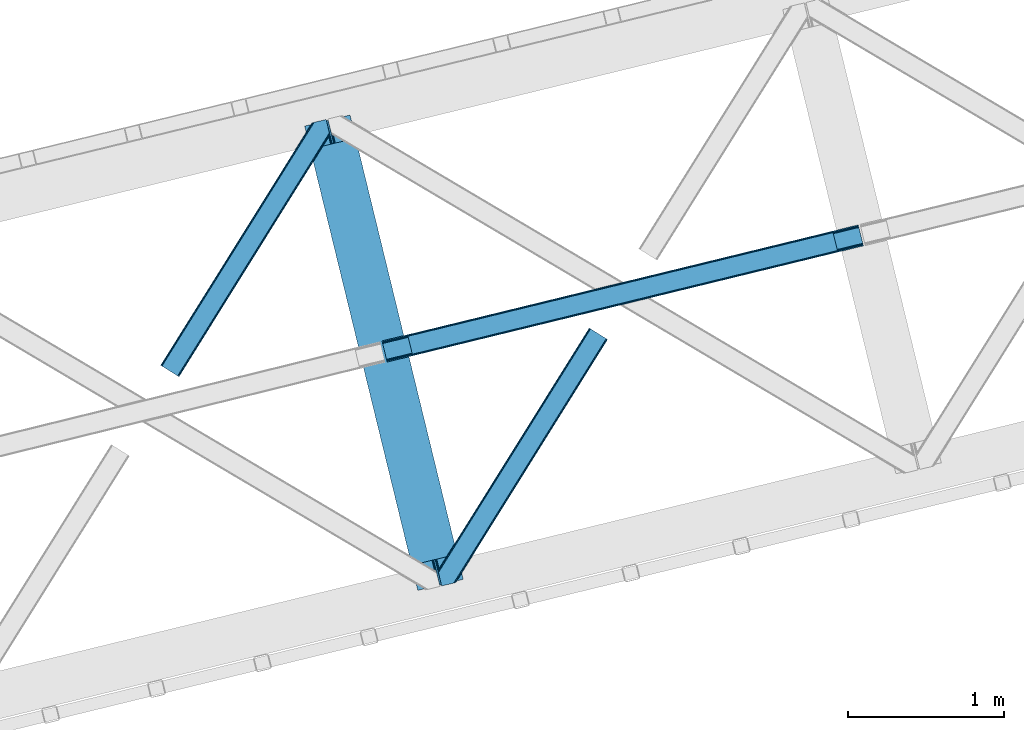
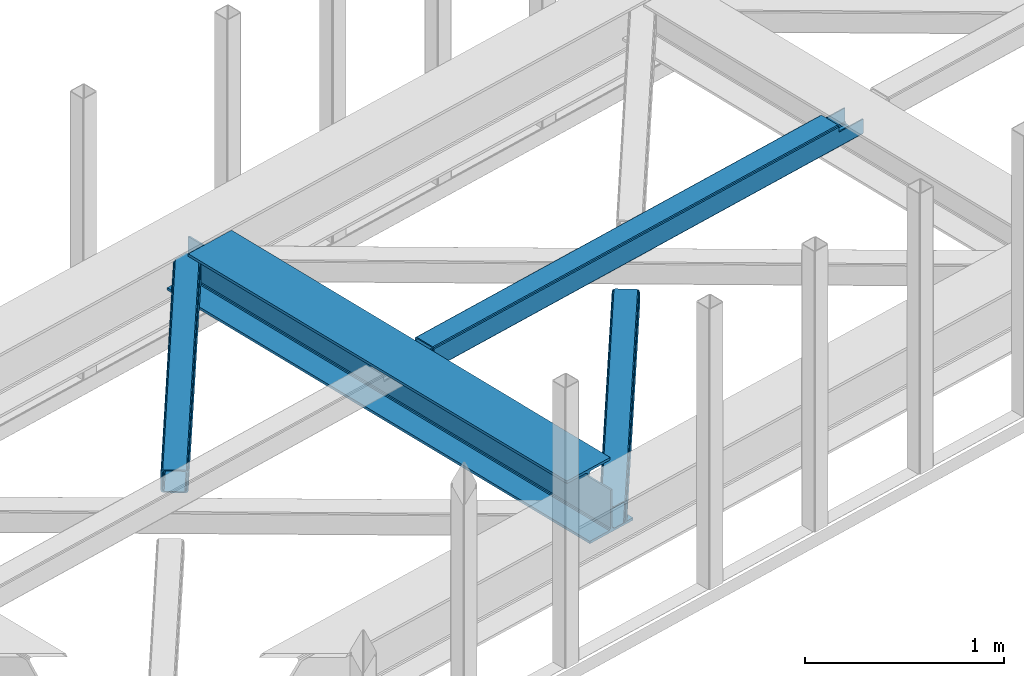
# One storey, part 40 of 67: 2 beams, 2 members.
"""IFC4 building model written with IfcOpenShell, lengths in millimetres."""

from ifc_helpers import new_model, entity, si_unit, converted_unit, derived_unit, direction, frame, origin, place, context, subcontext, project, spatial, triangles, polygons, material, type_object, element, save


model = new_model("IFC4")

# Units and contexts
model_context = context("Model", 3, precision=0.01, world=origin(), true_north=direction((6.12303176911189e-17, 1.0)))
plan_context = context("Plan", 3, precision=0.01, world=origin(), true_north=direction((6.12303176911189e-17, 1.0)))
body_context = subcontext(model_context, "Body", "Model", "MODEL_VIEW")
ifc_project = project(units=[si_unit("LENGTHUNIT", "METRE", prefix="MILLI"), si_unit("AREAUNIT", "SQUARE_METRE"), si_unit("VOLUMEUNIT", "CUBIC_METRE"), converted_unit("PLANEANGLEUNIT", "DEGREE", entity("IfcRatioMeasure", 0.0174532925199433), si_unit("PLANEANGLEUNIT", "RADIAN"), dimensions=[0, 0, 0, 0, 0, 0, 0]), si_unit("MASSUNIT", "GRAM", prefix="KILO"), derived_unit("MASSDENSITYUNIT", [(si_unit("MASSUNIT", "GRAM", prefix="KILO"), 1), (si_unit("LENGTHUNIT", "METRE"), -3)]), derived_unit("MOMENTOFINERTIAUNIT", [(si_unit("LENGTHUNIT", "METRE"), 4)]), si_unit("TIMEUNIT", "SECOND"), si_unit("FREQUENCYUNIT", "HERTZ"), si_unit("THERMODYNAMICTEMPERATUREUNIT", "DEGREE_CELSIUS"), derived_unit("THERMALTRANSMITTANCEUNIT", [(si_unit("MASSUNIT", "GRAM", prefix="KILO"), 1), (si_unit("THERMODYNAMICTEMPERATUREUNIT", "KELVIN"), -1), (si_unit("TIMEUNIT", "SECOND"), -3)]), derived_unit("VOLUMETRICFLOWRATEUNIT", [(si_unit("LENGTHUNIT", "METRE"), 3), (si_unit("TIMEUNIT", "SECOND"), -1)]), derived_unit("MASSFLOWRATEUNIT", [(si_unit("MASSUNIT", "GRAM", prefix="KILO"), 1), (si_unit("TIMEUNIT", "SECOND"), -1)]), derived_unit("ROTATIONALFREQUENCYUNIT", [(si_unit("TIMEUNIT", "SECOND"), -1)]), si_unit("ELECTRICCURRENTUNIT", "AMPERE"), si_unit("ELECTRICVOLTAGEUNIT", "VOLT"), si_unit("POWERUNIT", "WATT"), si_unit("FORCEUNIT", "NEWTON", prefix="KILO"), si_unit("ILLUMINANCEUNIT", "LUX"), si_unit("LUMINOUSFLUXUNIT", "LUMEN"), si_unit("LUMINOUSINTENSITYUNIT", "CANDELA"), derived_unit("USERDEFINED", [(si_unit("MASSUNIT", "GRAM", prefix="KILO"), -1), (si_unit("LENGTHUNIT", "METRE"), -2), (si_unit("TIMEUNIT", "SECOND"), 3), (si_unit("LUMINOUSFLUXUNIT", "LUMEN"), 1)]), derived_unit("LINEARVELOCITYUNIT", [(si_unit("LENGTHUNIT", "METRE"), 1), (si_unit("TIMEUNIT", "SECOND"), -1)]), si_unit("PRESSUREUNIT", "PASCAL"), derived_unit("USERDEFINED", [(si_unit("LENGTHUNIT", "METRE"), -2), (si_unit("MASSUNIT", "GRAM", prefix="KILO"), 1), (si_unit("TIMEUNIT", "SECOND"), -2)]), derived_unit("LINEARFORCEUNIT", [(si_unit("MASSUNIT", "GRAM", prefix="KILO"), 1), (si_unit("LENGTHUNIT", "METRE"), 1), (si_unit("TIMEUNIT", "SECOND"), -2), (si_unit("LENGTHUNIT", "METRE"), -1)]), derived_unit("PLANARFORCEUNIT", [(si_unit("MASSUNIT", "GRAM", prefix="KILO"), 1), (si_unit("LENGTHUNIT", "METRE"), 1), (si_unit("TIMEUNIT", "SECOND"), -2), (si_unit("LENGTHUNIT", "METRE"), -2)])], contexts=[model_context, plan_context])

# Site, building, storey
site_placement = place(None, origin())
site = spatial("IfcSite", under=ifc_project, at=site_placement, CompositionType="ELEMENT")
building_placement = place(site_placement, origin())
building = spatial("IfcBuilding", under=site, at=building_placement, CompositionType="ELEMENT")
storey_placement = place(building_placement, frame((0.0, 0.0, 19800.0)))
storey = spatial("IfcBuildingStorey", under=building, at=storey_placement, CompositionType="ELEMENT", Elevation=19800.0)

# Beams
ifc_material = material(Name="Metal painted (White)")
beam_type = type_object("IfcBeamType", PredefinedType="BEAM")
beam_1_placement = place(storey_placement, frame((-27234.9251460859, 11156.1280684599, 3807.02022389142)))
element("IfcBeam", 1, at=beam_1_placement, inside=storey, type_object=beam_type, material=ifc_material, ObjectType="Steel Beam", PredefinedType="BEAM", context=body_context, shape_type="Tessellation", body=[
    polygons([(1018.16648378329, 71.0478278970978, 15.5000000000008), (1018.16648378329, 71.0478278970978, 0.0), (291.465617442442, 3052.25531830421, 0.0), (291.465617442438, 3052.25531830421, 15.5000000000008), (894.779372399329, 40.970914087327, 15.5000000000008), (168.078506058478, 3022.17840449444, 15.5000000000008), (888.087028625371, 39.3395844888221, 16.8701684147984), (161.38616228452, 3020.54707489593, 16.8701684147984), (882.413533524751, 37.9566100336497, 20.7720779386434), (155.7126671839, 3019.16410044076, 20.7720779386434), (878.622625296176, 37.0325360459162, 26.6116982174294), (151.921758955325, 3018.24002645303, 26.6116982174294), (877.291435352783, 36.7080444135007, 33.500000000001), (150.590569011928, 3017.91553482061, 33.500000000001), (140.875048430518, 3015.54727389071, 33.500000000001), (140.875048430518, 3015.54727389071, 259.000000000002), (150.590569011928, 3017.91553482061, 259.000000000002), (0.0, 2981.20749040711, 0.0), (0.0, 2981.20749040711, 15.4999999999965), (123.387111383968, 3011.28440421688, 15.5000000000008), (130.079455157922, 3012.91573381539, 16.8701684147984), (135.752950258546, 3014.29870827056, 20.7720779386391), (139.543858487122, 3015.2227822583, 26.6116982174294), (877.291435352783, 36.7080444135007, 259.000000000002), (867.575914771365, 34.3397834835992, 259.000000000002), (867.575914771365, 34.3397834835992, 33.500000000001), (866.244724827968, 34.0152918511816, 26.6116982174294), (862.453816599393, 33.0912178634481, 20.7720779386391), (856.780321498769, 31.7082434082757, 16.8701684147984), (850.087977724815, 30.076913809773, 15.5000000000008), (726.700866340847, 0.0, 15.4999999999965), (726.700866340847, -2.16573425859679e-12, 0.0), (838.124523615916, 197.385937999179, 259.069791973884), (186.469722099971, 2870.72539801218, 259.000000000002), (186.693115201825, 2869.80895360721, 259.617303331124), (186.70550404545, 2869.75812937344, 266.500003008253), (837.979344808147, 197.981416001704, 266.500002998871), (837.979694928895, 197.979979696968, 260.000004007589), (828.499586345876, 194.645865944429, 259.006343171919), (828.276216326107, 195.562317481909, 259.617303331124), (828.263827482481, 195.613141715683, 266.500003008253), (176.989986719784, 2867.38985508742, 266.500002998871), (176.989636599036, 2867.39129139215, 260.000004007589), (176.844830940692, 2867.98534020594, 259.07612046749), (176.754201518548, 2868.35713708228, 259.000000000002), (839.310832678066, 198.304685446386, 273.388305639783), (843.101109266766, 199.231350618303, 279.227924098781), (848.7741802143, 200.616065081979, 283.129832400619), (855.466371895434, 202.24801861279, 284.500000377228), (978.853400583269, 232.3252716679, 284.500000138971), (978.851730776613, 232.332121736633, 299.999995328161), (687.386308679343, 161.283492472591, 299.999995890962), (687.387978486003, 161.276642403861, 284.500000701776), (810.775007173847, 191.353895458972, 284.500000463519), (817.467494069986, 192.984637925548, 283.129832461069), (823.141405718746, 194.365903570074, 279.227924137322), (826.932940505738, 195.28740721937, 273.388305663684), (175.658498849852, 2867.06658564273, 273.388305639783), (171.868222261156, 2866.13992047082, 279.227924098781), (166.195151313627, 2864.75520600714, 283.129832400619), (159.502959632497, 2863.12325247633, 284.500000377228), (36.115930944649, 2833.04599942122, 284.500000138971), (36.1176007513094, 2833.03914935249, 299.999995328161), (327.583022848575, 2904.08777861653, 299.999995890962), (327.581353041919, 2904.09462868526, 284.500000701776), (204.194324354084, 2874.01737563015, 284.500000463519), (197.501837457941, 2872.38663316357, 283.129832461069), (191.827925809181, 2871.00536751904, 279.227924137322), (188.036391022185, 2870.08386386975, 273.388305663684)], [[[1, 2, 3, 4]], [[5, 1, 4, 6]], [[7, 5, 6, 8]], [[9, 7, 8, 10]], [[11, 9, 10, 12]], [[13, 11, 12, 14]], [[15, 16, 17, 14, 12, 10, 8, 6, 4, 3, 18, 19, 20, 21, 22, 23]], [[13, 24, 25, 26, 27, 28, 29, 30, 31, 32, 2, 1, 5, 7, 9, 11]], [[2, 32, 18, 3]], [[32, 31, 19, 18]], [[31, 30, 20, 19]], [[27, 26, 15, 23]], [[28, 27, 23, 22]], [[29, 28, 22, 21]], [[30, 29, 21, 20]], [[33, 24, 13, 14, 17, 34, 35, 36, 37, 38]], [[25, 39, 40, 41, 42, 43, 44, 16, 15, 26]], [[39, 25, 24, 33]], [[45, 34, 17, 16]], [[41, 40, 38, 37, 46, 47, 48, 49, 50, 51, 52, 53, 54, 55, 56, 57]], [[42, 58, 59, 60, 61, 62, 63, 64, 65, 66, 67, 68, 69, 36, 35, 43]], [[46, 37, 36, 69]], [[47, 46, 69, 68]], [[48, 47, 68, 67]], [[49, 48, 67, 66]], [[50, 49, 66, 65]], [[51, 50, 65, 64]], [[52, 51, 64, 63]], [[53, 52, 63, 62]], [[54, 53, 62, 61]], [[55, 54, 61, 60]], [[56, 55, 60, 59]], [[57, 56, 59, 58]], [[41, 57, 58, 42]]], closed=False),
])
beam_2_placement = place(storey_placement, frame((-26738.1889944825, 12622.2260164925, 3967.02022389142)))
element("IfcBeam", 2, at=beam_2_placement, inside=storey, type_object=beam_type, material=ifc_material, ObjectType="Steel Beam", PredefinedType="BEAM", context=body_context, shape_type="Tessellation", body=[
    polygons([(31.1823923917614, 8.09507685196108, 17.8030399336114), (31.4978703677143, 6.80086440699217, 24.4999999999988), (3089.94374939705, 752.329405140566, 24.4999999999988), (3089.62827142109, 753.623617585535, 17.8030399336114), (30.2839871259035, 11.7806820741864, 12.1256313292298), (3088.72986615524, 757.309222807764, 12.1256313292298), (28.9394286278148, 17.2965800886753, 8.33210818105214), (3087.38530765716, 762.825120822251, 8.33210818105214), (27.3534137403861, 23.8030254244661, 7.00000000000274), (3085.79929276972, 769.331566158042, 7.00000000000274), (4.21622439082827, 118.720708051131, 8.33210818105214), (5.80223927826556, 112.214262715341, 7.00000000000274), (3064.2481183076, 857.742803448919, 7.00000000000274), (3062.66210342017, 864.249248784707, 8.33210818105214), (2.87166589274391, 124.236606065618, 12.1256313292342), (3061.31754492208, 869.765146799196, 12.1256313292342), (1.9732606268946, 127.922211287846, 17.8030399336114), (3060.41913965623, 873.450752021424, 17.8030399336114), (1.65778265093302, 129.216423732817, 24.4999999999988), (3060.10366168026, 874.744964466395, 24.4999999999988), (33.1556530186517, 0.0, 17.5000000000004), (33.1556530186517, 0.0, 99.499999999999), (31.497870367723, 6.80086440699001, 99.499999999999), (1.65778265093735, 129.216423732817, 99.499999999999), (4.33146851719357e-12, 136.017288139807, 99.499999999999), (4.33146851719357e-12, 136.017288139807, 17.5000000000004), (0.315477975965916, 134.723075694838, 10.803039933613), (1.21388324181955, 131.037470472612, 5.12563132923143), (2.55844173990391, 125.521572458124, 1.33210818105373), (4.14445662733254, 119.015127122331, 0.0), (29.0111963913192, 17.0021610174761, 0.0), (30.5972112787564, 10.4957156816853, 1.33210818105373), (31.9417697768408, 4.97981766719418, 5.12563132923576), (32.8401750426901, 1.29421244496891, 10.803039933613), (3058.44587902933, 881.54582887338, 17.5000000000004), (3058.44587902933, 881.54582887338, 99.499999999999), (3060.10366168026, 874.74496446639, 99.499999999999), (3089.94374939704, 752.329405140566, 99.499999999999), (3091.60153204797, 745.528540733574, 99.499999999999), (3091.60153204797, 745.528540733574, 17.5000000000004), (3091.28605407202, 746.822753178543, 10.803039933613), (3090.38764880616, 750.508358400766, 5.12563132923576), (3089.04309030808, 756.024256415259, 1.33210818105373), (3087.45707542064, 762.53070175105, 0.0), (3062.59033565666, 864.543667855904, 0.0), (3061.00432076922, 871.050113191697, 1.33210818105373), (3059.65976227114, 876.566011206186, 5.12563132923143), (3058.76135700529, 880.251616428411, 10.803039933613), (2925.75994180941, 712.307865540878, 115.5000123926), (2925.81630989428, 712.321604759496, 100.117303289864), (2926.72300362928, 712.542621518191, 99.499999999999), (194.718606580805, 46.5876811586757, 99.5063429816656), (195.631369831917, 46.8101414945052, 100.117301735448), (195.690168193631, 46.824474122359, 115.5), (2928.38078628021, 705.741757111199, 99.499999999999), (2927.47422618797, 705.520772937691, 100.117303484932), (2927.41464342029, 705.506249905349, 122.500007895425), (197.345360928052, 40.0229783796067, 122.500002534479), (197.338587096745, 40.02132714415, 100.500009163303), (196.74820519572, 39.8773799905087, 99.5697919021647), (2896.88292546718, 834.958147714707, 99.5063429816656), (2895.97381660772, 834.736577551995, 100.117299778624), (2895.91744852285, 834.722838333377, 115.50000888136), (165.850080476841, 169.240033448183, 115.5), (165.840462203343, 169.237688832044, 100.50000941238), (165.250325295037, 169.093836777333, 99.5761204674868), (2894.85332685227, 841.668448882878, 99.5697919021647), (163.220745767773, 175.804071762186, 99.499999999999), (164.133244938519, 176.026503182399, 100.117301984524), (164.189439987632, 176.040201208968, 122.500002796667), (2894.25631754634, 841.522886341455, 122.500003994045), (2894.26642083517, 841.525349756027, 100.500018741102), (2894.56843170073, 840.227853719294, 129.196959150505), (2895.46176722632, 836.541012377604, 134.874360354937), (2896.80305823039, 831.024317672795, 138.667878733795), (2898.38810531639, 824.51763636472, 139.999985502214), (2923.25885436332, 722.505647815409, 139.999991354279), (2924.84634848091, 715.999563150004, 138.667885332354), (2926.19460804134, 710.484567539777, 134.874367586349), (2927.09837274855, 706.800269072823, 129.196966804773), (2925.44675217771, 713.602635936895, 122.196975799125), (2924.54298747049, 717.286934403852, 127.874376580702), (2923.19472791006, 722.801930014079, 131.667894326702), (2921.60723379248, 729.308014679482, 133.000000348631), (2900.05258461847, 817.71840475555, 132.999995276841), (2898.46753753246, 824.225086063627, 131.667888508414), (2897.1262465284, 829.74178076843, 127.874370129564), (2896.23291100281, 833.428622110126, 122.196968925133), (164.878528418706, 169.003207355194, 99.499999999999), (193.131726453732, 57.3201898040399, 131.667891818946), (191.545711566294, 63.8266351398329, 133.0), (194.476284951812, 51.8042917895531, 127.874368670764), (195.37469021767, 48.1186865673279, 122.196960066391), (169.994537104174, 152.237872430709, 133.0), (166.165558452803, 167.945821003215, 122.196960066391), (167.063963718652, 164.260215780989, 127.874368670764), (168.408522216736, 158.744317766502, 131.667891818946), (197.031411944078, 41.3175635421159, 129.196961104604), (196.136488323061, 45.0040174739024, 134.874366301861), (194.794244157319, 50.5204796458751, 138.667887185257), (193.209023953586, 57.0271186992015, 139.999994588639), (168.341882306941, 159.039986838392, 139.999994981919), (166.755021471189, 165.546225960036, 138.667887628704), (165.408105180735, 171.06154922293, 134.874366787843), (164.506189230965, 174.746298656828, 129.196961619)], [[[1, 2, 3, 4]], [[5, 1, 4, 6]], [[7, 5, 6, 8]], [[9, 7, 8, 10]], [[11, 12, 13, 14]], [[15, 11, 14, 16]], [[17, 15, 16, 18]], [[19, 17, 18, 20]], [[12, 9, 10, 13]], [[21, 22, 23, 2, 1, 5, 7, 9, 12, 11, 15, 17, 19, 24, 25, 26, 27, 28, 29, 30, 31, 32, 33, 34]], [[35, 36, 37, 20, 18, 16, 14, 13, 10, 8, 6, 4, 3, 38, 39, 40, 41, 42, 43, 44, 45, 46, 47, 48]], [[49, 50, 51, 38, 3, 2, 23, 52, 53, 54]], [[55, 39, 38, 51]], [[39, 55, 56, 57, 58, 59, 60, 22, 21, 40]], [[32, 31, 44, 43]], [[33, 32, 43, 42]], [[34, 33, 42, 41]], [[21, 34, 41, 40]], [[31, 30, 45, 44]], [[27, 26, 35, 48]], [[28, 27, 48, 47]], [[29, 28, 47, 46]], [[30, 29, 46, 45]], [[20, 37, 61, 62, 63, 64, 65, 66, 24, 19]], [[67, 36, 35, 26, 25, 68, 69, 70, 71, 72]], [[36, 67, 61, 37]], [[72, 71, 73, 74, 75, 76, 77, 78, 79, 80, 57, 56, 50, 49, 81, 82, 83, 84, 85, 86, 87, 88, 63, 62]], [[60, 52, 23, 22]], [[25, 24, 89, 68]], [[90, 91, 84, 83]], [[92, 90, 83, 82]], [[93, 92, 82, 81]], [[54, 93, 81, 49]], [[94, 85, 84, 91]], [[95, 64, 63, 88]], [[96, 95, 88, 87]], [[97, 96, 87, 86]], [[94, 97, 86, 85]], [[65, 64, 95, 96, 97, 94, 91, 90, 92, 93, 54, 53, 59, 58, 98, 99, 100, 101, 102, 103, 104, 105, 70, 69]], [[98, 58, 57, 80]], [[99, 98, 80, 79]], [[100, 99, 79, 78]], [[101, 100, 78, 77]], [[77, 76, 102, 101]], [[103, 102, 76, 75]], [[104, 103, 75, 74]], [[105, 104, 74, 73]], [[70, 105, 73, 71]]], closed=False),
])

# Members
member_type_1 = type_object("IfcMemberType", PredefinedType="BRACE")
member_1_placement = place(storey_placement, frame((-28160.1625305176, 12527.4864990234, 3822.99993896484)))
element("IfcMember", 3, at=member_1_placement, inside=storey, type_object=member_type_1, ObjectType="Steel Horizontal Brace", PredefinedType="BRACE", context=body_context, shape_type="Tessellation", body=[
    triangles([(933.019793701173, 1535.69230957031, 0.0), (967.780462646486, 1393.09171142578, 0.0), (14.8479309082031, 64.8704589843746, 0.0), (103.9169128418, 9.2680389404286, 0.0), (928.803771972656, 1552.99125366211, 5.49966430664063), (928.943298339844, 1552.41687011719, 5.208984375), (930.803649902344, 1544.78710327148, 1.33247680664135), (971.998809814453, 1375.79276733398, 5.49966430664063), (971.856958007815, 1376.36715087891, 5.208984375), (969.998931884766, 1383.99691772461, 1.33247680664135), (972.210424804689, 1375.53813171387, 5.8531311035149), (972.424365234376, 1375.28349609375, 6.20659790039281), (928.915393066407, 1553.57028808594, 5.74383544921875), (972.726672363282, 1375.53813171387, 6.35310058593677), (929.029339599612, 1554.1772277832, 5.9996337890625), (973.026654052737, 1375.79276733398, 6.49960327148438), (929.145611572269, 1554.78416748047, 6.25543212890625), (929.254907226565, 1555.36203918457, 6.49960327148438), (4.34857177734375, 71.4223846435543, 5.12526855468968), (1.13248901367479, 73.4315643310547, 10.8039916992202), (973.361517333986, 1630.84347839355, 10.8039916992202), (976.917114257813, 1631.70970458984, 6.49960327148438), (9.16455688476708, 68.415591430663, 1.33247680664135), (971.508142089846, 1630.39118041992, 17.5012573242202), (0.0, 74.1373352050778, 17.5012573242202), (1081.10145263672, 1548.91708374023, 6.49960327148438), (1056.20762329102, 1651.03759460449, 6.49960327148438), (971.508142089846, 1630.39118041992, 122.499499511719), (0.0, 74.1373352050778, 122.499499511719), (973.361517333986, 1630.84347839355, 129.196765136719), (1.13248901367479, 73.4315643310547, 129.196765136719), (978.633288574219, 1632.12828369141, 134.87548828125), (4.34857177734375, 71.4223846435543, 134.87548828125), (986.530480957033, 1634.05374755859, 138.668280029298), (9.16455688476708, 68.415591430663, 138.668280029298), (995.841540527344, 1636.32221374512, 140.00075683594), (14.8479309082031, 64.8704589843746, 140.00075683594), (118.760192871094, 0.0, 17.5012573242202), (117.632354736328, 0.705770874023074, 10.8039916992202), (1085.14306640625, 1551.25066223144, 10.9783996582046), (1087.41734619141, 1552.56453552246, 13.4991760253906), (109.597961425781, 5.7205810546875, 1.33247680664135), (114.413946533205, 2.71495056152344, 5.12526855468968), (1087.57082519531, 1551.93550415039, 17.5012573242202), (1081.77815551758, 1575.70265808105, 140.00075683594), (1063.00953369141, 1652.69563293457, 140.00075683594), (103.9169128418, 9.2680389404286, 140.00075683594), (1083.99429931641, 1566.60670166016, 138.668280029298), (109.597961425781, 5.7205810546875, 138.668280029298), (1085.87325439453, 1558.89670715332, 134.87548828125), (114.413946533205, 2.71495056152344, 134.87548828125), (1087.12899169922, 1553.74469604492, 129.196765136719), (117.632354736328, 0.705770874023074, 129.196765136719), (1087.57082519531, 1551.93550415039, 122.499499511719), (118.760192871094, 0.0, 122.499499511719), (1082.53857421875, 1566.77413330078, 12.1248413085959), (1083.96639404297, 1566.72413635254, 13.4991760253906), (1077.8528137207, 1569.98556518555, 8.3320495605476), (1074.6483581543, 1577.50138549805, 6.99957275390625), (1056.69364013672, 1651.1561920166, 6.99957275390625), (1005.57350463867, 1638.69532470703, 6.99957275390625), (20.784777832032, 61.1625457763676, 6.99957275390625), (97.9777404785164, 12.9736267089847, 6.99957275390625), (108.474774169925, 6.42170104980505, 12.1248413085959), (111.693182373048, 4.41252136230469, 17.8035644531265), (1084.81285400391, 1563.2510925293, 17.8035644531265), (103.661114501956, 9.42849426269458, 8.3320495605476), (1085.25236206055, 1561.44190063477, 24.5008300781265), (112.823345947269, 3.70791320800708, 24.5008300781265), (983.093481445314, 1633.21542663574, 17.8035644531265), (981.240106201174, 1632.76429138184, 24.5008300781265), (7.0693359375, 69.7248138427731, 17.8035644531265), (5.94149780273438, 70.4305847167961, 24.5008300781265), (988.369903564453, 1634.50139465332, 12.1248413085959), (10.2877441406272, 67.7156341552727, 12.1248413085959), (996.262445068362, 1636.42569580078, 8.3320495605476), (15.1037292480469, 64.7100036621086, 8.3320495605476), (981.240106201174, 1632.76429138184, 115.499926757813), (5.94149780273438, 70.4305847167961, 115.499926757813), (996.262445068362, 1636.42569580078, 131.668707275392), (1005.57350463867, 1638.69532470703, 133.001184082033), (1063.00953369141, 1652.69563293457, 133.001184082033), (988.369903564453, 1634.50139465332, 127.873590087893), (983.093481445314, 1633.21542663574, 122.197192382813), (20.784777832032, 61.1625457763676, 133.001184082033), (15.1037292480469, 64.7100036621086, 131.668707275392), (10.2877441406272, 67.7156341552727, 127.873590087893), (7.0693359375, 69.7248138427731, 122.197192382813), (108.474774169925, 6.42170104980505, 127.873590087893), (111.693182373048, 4.41252136230469, 122.197192382813), (112.823345947269, 3.70791320800708, 115.499926757813), (97.9777404785164, 12.9736267089847, 133.001184082033), (103.661114501956, 9.42849426269458, 131.668707275392), (1085.25236206055, 1561.44190063477, 115.499926757813), (1084.81285400391, 1563.2510925293, 122.197192382813), (1083.55711669922, 1568.40310363769, 127.873590087893), (1081.67583618164, 1576.11309814453, 131.668707275392), (1079.45969238281, 1585.20905456543, 133.001184082033)], [[1, 2, 3], [4, 3, 2], [1, 5, 2], [6, 5, 1], [1, 7, 6], [2, 5, 8], [8, 9, 2], [10, 2, 9], [11, 8, 5], [12, 11, 13], [14, 12, 15], [16, 14, 17], [17, 18, 16], [15, 17, 14], [13, 15, 12], [5, 13, 11], [17, 19, 18], [19, 17, 15], [13, 19, 15], [19, 13, 5], [5, 6, 19], [20, 21, 18], [18, 19, 20], [21, 22, 18], [19, 6, 7], [7, 1, 23], [3, 23, 1], [7, 23, 19], [24, 21, 20], [20, 25, 24], [18, 26, 16], [26, 18, 22], [27, 26, 22], [28, 24, 25], [25, 29, 28], [30, 28, 31], [29, 31, 28], [32, 30, 33], [31, 33, 30], [34, 32, 35], [33, 35, 32], [36, 34, 37], [35, 37, 34], [38, 39, 40], [40, 41, 38], [42, 10, 9], [39, 12, 16], [16, 40, 39], [16, 26, 40], [9, 39, 43], [9, 12, 39], [9, 43, 42], [2, 10, 4], [42, 4, 10], [41, 44, 38], [45, 36, 37], [36, 45, 46], [37, 47, 45], [48, 45, 47], [47, 49, 48], [50, 48, 49], [49, 51, 50], [52, 50, 51], [51, 53, 52], [54, 52, 53], [53, 55, 54], [44, 54, 55], [55, 38, 44], [56, 40, 26], [41, 40, 56], [56, 57, 41], [58, 26, 59], [26, 58, 56], [60, 59, 26], [59, 61, 62], [61, 59, 60], [62, 63, 59], [64, 65, 66], [66, 57, 64], [58, 59, 63], [63, 67, 58], [56, 58, 67], [67, 64, 56], [57, 56, 64], [68, 66, 65], [65, 69, 68], [70, 71, 72], [73, 72, 71], [74, 70, 75], [72, 75, 70], [76, 74, 77], [75, 77, 74], [61, 76, 62], [77, 62, 76], [71, 78, 73], [79, 73, 78], [34, 36, 80], [46, 81, 36], [81, 46, 82], [81, 80, 36], [83, 34, 80], [83, 32, 34], [32, 84, 30], [84, 32, 83], [28, 84, 78], [84, 28, 30], [61, 22, 76], [70, 74, 22], [74, 76, 22], [61, 60, 22], [71, 70, 24], [21, 24, 70], [28, 71, 24], [71, 28, 78], [70, 22, 21], [80, 81, 85], [85, 86, 80], [83, 80, 86], [86, 87, 83], [84, 83, 87], [87, 88, 84], [78, 84, 88], [88, 79, 78], [53, 89, 90], [91, 38, 55], [53, 90, 55], [53, 51, 89], [90, 91, 55], [89, 51, 49], [92, 47, 37], [47, 93, 49], [93, 47, 92], [93, 89, 49], [39, 64, 43], [69, 38, 91], [38, 65, 39], [65, 38, 69], [39, 65, 64], [4, 63, 3], [42, 43, 64], [64, 67, 42], [67, 63, 4], [4, 42, 67], [87, 35, 33], [37, 85, 92], [37, 86, 85], [86, 37, 35], [87, 86, 35], [79, 29, 25], [31, 88, 87], [33, 31, 87], [88, 31, 29], [79, 88, 29], [23, 75, 19], [3, 63, 62], [62, 77, 3], [77, 75, 23], [23, 3, 77], [20, 19, 75], [25, 73, 79], [72, 25, 20], [25, 72, 73], [72, 20, 75], [66, 41, 57], [54, 44, 68], [44, 66, 68], [68, 94, 54], [44, 41, 66], [95, 54, 94], [52, 54, 95], [50, 95, 96], [95, 50, 52], [96, 48, 50], [97, 48, 96], [97, 98, 45], [97, 45, 48], [98, 46, 45], [98, 82, 46], [81, 98, 85], [81, 82, 98], [92, 85, 98], [95, 94, 90], [91, 90, 94], [96, 95, 89], [90, 89, 95], [97, 96, 93], [89, 93, 96], [98, 97, 92], [93, 92, 97], [94, 68, 91], [69, 91, 68]]),
])
member_type_2 = type_object("IfcMemberType", PredefinedType="BRACE")
member_2_placement = place(storey_placement, frame((-26379.092175293, 11184.3289489746, 3822.99993896484)))
element("IfcMember", 4, at=member_2_placement, inside=storey, type_object=member_type_2, ObjectType="Steel Horizontal Brace", PredefinedType="BRACE", context=body_context, shape_type="Tessellation", body=[
    triangles([(986.153759765624, 1647.42967529297, 0.0), (1075.22274169922, 1591.82725524902, 0.0), (119.788037109374, 259.603921508789, 0.0), (154.548706054688, 117.003323364259, 0.0), (115.902227783201, 275.544808959961, 4.52065429687718), (117.571893310545, 268.698715209961, 1.33247680664135), (158.434515380857, 101.062435913087, 4.52065429687718), (156.764849853513, 107.908529663086, 1.33247680664135), (114.825549316403, 275.742471313477, 5.52059326172093), (115.130181884764, 275.923855590821, 5.35316162109302), (158.132208251951, 99.1218566894531, 5.27642211914281), (115.439465332031, 276.107565307617, 5.18107910156323), (158.232202148436, 99.7776306152355, 5.02062377929906), (158.188018798828, 99.4822998046875, 5.13457031250073), (115.541784667967, 276.1680267334, 5.12526855468968), (115.683636474609, 275.921530151367, 4.88574829101708), (158.336846923827, 100.433404541016, 4.76482543945531), (158.032214355466, 98.4928253173839, 5.52059326172093), (1085.71977539062, 1585.27416687012, 5.12526855468968), (1080.90146484375, 1588.28096008301, 1.33247680664135), (1088.93818359375, 1583.26498718262, 10.8039916992202), (114.21163330078, 21.8533172607422, 10.8039916992202), (109.467736816405, 20.6964111328125, 5.52059326172093), (1090.06602172851, 1582.56037902832, 17.5012573242202), (116.062683105469, 22.3044525146488, 17.5012573242202), (6.75307617187354, 102.619317626953, 5.52059326172093), (31.3632019042961, 1.65803833007885, 5.52059326172093), (1090.06602172851, 1582.56037902832, 122.499499511719), (116.062683105469, 22.3044525146488, 122.499499511719), (1088.93818359375, 1583.26498718262, 129.196765136719), (114.21163330078, 21.8533172607422, 129.196765136719), (1085.71977539062, 1585.27416687012, 134.87548828125), (108.935211181641, 20.5673492431652, 134.87548828125), (1080.90146484375, 1588.28096008301, 138.668280029298), (101.042669677732, 18.6430480957042, 138.668280029298), (1075.22274169922, 1591.82725524902, 140.00075683594), (91.7292846679666, 16.3722564697273, 140.00075683594), (980.472711181639, 1650.97597045899, 1.33247680664135), (975.656726074216, 1653.98276367187, 5.12526855468968), (1.69059448242115, 100.411312866212, 10.9621215820334), (972.438317871092, 1655.99078063965, 10.8039916992202), (971.308154296872, 1656.69655151367, 17.5012573242202), (0.239520263668965, 99.7776306152355, 12.5201660156272), (0.0, 100.760128784181, 17.5012573242202), (5.79266967773219, 76.9941375732433, 140.00075683594), (986.153759765624, 1647.42967529297, 140.00075683594), (24.5612915039055, 0.0, 140.00075683594), (971.308154296872, 1656.69655151367, 122.499499511719), (0.0, 100.760128784181, 122.499499511719), (980.472711181639, 1650.97597045899, 138.668280029298), (3.57652587890334, 86.0889312744148, 138.668280029298), (975.656726074216, 1653.98276367187, 134.87548828125), (1.69524536132667, 93.7989257812496, 134.87548828125), (972.438317871092, 1655.99078063965, 129.196765136719), (0.43950805663917, 98.9509368896488, 129.196765136719), (29.9237548828096, 1.30689697265734, 6.99957275390625), (12.1969299316406, 74.0326904296871, 6.99957275390625), (8.99247436523365, 81.5485107421882, 8.3320495605476), (3.88580932616969, 84.8122650146488, 12.5201660156272), (1069.28589477539, 1595.53400573731, 6.99957275390625), (81.9949951171875, 14.0003082275398, 6.99957275390625), (992.090606689453, 1643.72292480469, 6.99957275390625), (981.593572998045, 1650.27601318359, 12.1248413085959), (978.375164794921, 1652.28403015137, 17.8035644531265), (2.75797119140407, 89.4445404052731, 17.8035644531265), (986.409558105468, 1647.2692199707, 8.3320495605476), (977.245001220701, 1652.98980102539, 24.5008300781265), (2.31613769531032, 91.2537322998051, 24.5008300781265), (977.245001220701, 1652.98980102539, 115.499926757813), (2.31613769531032, 91.2537322998051, 115.499926757813), (4.01370849609157, 84.2925292968757, 127.873590087893), (2.75797119140407, 89.4445404052731, 122.197192382813), (5.89266357421729, 76.5825347900391, 131.668707275392), (8.10880737304615, 67.4865783691403, 133.001184082033), (24.5612915039055, 0.0, 133.001184082033), (978.375164794921, 1652.28403015137, 122.197192382813), (981.593572998045, 1650.27601318359, 127.873590087893), (986.409558105468, 1647.2692199707, 131.668707275392), (992.090606689453, 1643.72292480469, 133.001184082033), (1069.28589477539, 1595.53400573731, 133.001184082033), (81.9949951171875, 14.0003082275398, 133.001184082033), (1079.78060302734, 1588.9809173584, 12.1248413085959), (1082.99901123047, 1586.97290039063, 17.8035644531265), (1084.12917480469, 1586.2671295166, 24.5008300781265), (1074.96461791992, 1591.98771057129, 8.3320495605476), (1079.78060302734, 1588.9809173584, 127.873590087893), (1084.12917480469, 1586.2671295166, 115.499926757813), (1082.99901123047, 1586.97290039063, 122.197192382813), (1074.96461791992, 1591.98771057129, 131.668707275392), (91.3083801269531, 16.2699371337894, 131.668707275392), (99.2032470703125, 18.1942382812504, 127.873590087893), (104.477343749997, 19.4802062988292, 122.197192382813), (106.330718994141, 19.9325042724613, 115.499926757813), (91.3083801269531, 16.2699371337894, 8.3320495605476), (104.477343749997, 19.4802062988292, 17.8035644531265), (99.2032470703125, 18.1942382812504, 12.1248413085959), (106.330718994141, 19.9325042724613, 24.5008300781265)], [[1, 2, 3], [4, 3, 2], [5, 3, 4], [3, 5, 6], [4, 7, 5], [7, 4, 8], [9, 10, 11], [10, 12, 13], [13, 14, 10], [12, 15, 16], [16, 17, 12], [16, 5, 7], [7, 17, 16], [17, 13, 12], [14, 11, 10], [11, 18, 9], [19, 14, 13], [13, 20, 19], [13, 17, 20], [17, 7, 20], [7, 8, 20], [21, 22, 18], [18, 19, 21], [14, 19, 11], [18, 11, 19], [22, 23, 18], [21, 24, 25], [25, 22, 21], [2, 20, 4], [8, 4, 20], [23, 26, 18], [23, 27, 26], [9, 18, 26], [24, 28, 29], [29, 25, 24], [28, 30, 29], [31, 29, 30], [30, 32, 31], [33, 31, 32], [32, 34, 33], [35, 33, 34], [34, 36, 35], [37, 35, 36], [38, 6, 5], [5, 39, 38], [5, 15, 39], [40, 41, 9], [41, 39, 15], [42, 41, 40], [40, 43, 42], [43, 44, 42], [9, 26, 40], [38, 1, 6], [3, 6, 1], [36, 45, 37], [36, 46, 45], [45, 47, 37], [48, 42, 44], [44, 49, 48], [46, 50, 51], [51, 45, 46], [50, 52, 53], [53, 51, 50], [52, 54, 55], [55, 53, 52], [54, 48, 49], [49, 55, 54], [27, 56, 57], [26, 57, 58], [57, 26, 27], [59, 40, 26], [26, 58, 59], [43, 40, 59], [60, 57, 61], [60, 62, 57], [57, 56, 61], [63, 64, 65], [65, 59, 63], [66, 63, 59], [62, 66, 58], [58, 57, 62], [59, 58, 66], [64, 67, 68], [68, 65, 64], [67, 69, 70], [70, 68, 67], [71, 53, 72], [73, 74, 45], [74, 47, 45], [74, 75, 47], [51, 73, 45], [71, 51, 53], [71, 73, 51], [49, 68, 70], [55, 72, 53], [70, 72, 49], [72, 55, 49], [44, 68, 49], [43, 59, 65], [65, 68, 44], [44, 43, 65], [69, 76, 70], [72, 70, 76], [76, 77, 72], [71, 72, 77], [77, 78, 71], [73, 71, 78], [78, 79, 73], [74, 73, 79], [80, 74, 79], [74, 80, 81], [75, 74, 81], [21, 82, 83], [84, 28, 24], [21, 83, 24], [21, 19, 82], [83, 84, 24], [82, 19, 20], [60, 2, 1], [2, 85, 20], [85, 2, 60], [85, 82, 20], [30, 86, 32], [87, 28, 84], [28, 88, 30], [88, 28, 87], [30, 88, 86], [36, 80, 46], [34, 32, 86], [86, 89, 34], [89, 80, 36], [36, 34, 89], [63, 38, 39], [1, 62, 60], [1, 66, 62], [66, 1, 38], [63, 66, 38], [67, 42, 48], [41, 64, 63], [39, 41, 63], [64, 41, 42], [67, 64, 42], [50, 77, 52], [46, 80, 79], [79, 78, 46], [78, 77, 50], [50, 46, 78], [54, 52, 77], [48, 69, 67], [76, 48, 54], [48, 76, 69], [76, 54, 77], [35, 37, 90], [47, 81, 37], [81, 47, 75], [81, 90, 37], [91, 35, 90], [91, 33, 35], [33, 92, 31], [92, 33, 91], [29, 92, 93], [92, 29, 31], [61, 23, 94], [95, 96, 23], [96, 94, 23], [61, 27, 23], [27, 61, 56], [97, 95, 25], [22, 25, 95], [29, 97, 25], [97, 29, 93], [95, 23, 22], [80, 89, 90], [90, 81, 80], [89, 86, 91], [91, 90, 89], [86, 88, 92], [92, 91, 86], [88, 87, 93], [93, 92, 88], [87, 84, 97], [97, 93, 87], [84, 83, 97], [95, 97, 83], [83, 82, 95], [96, 95, 82], [82, 85, 96], [94, 96, 85], [85, 60, 94], [61, 94, 60]]),
])

save(model, "model.ifc")
